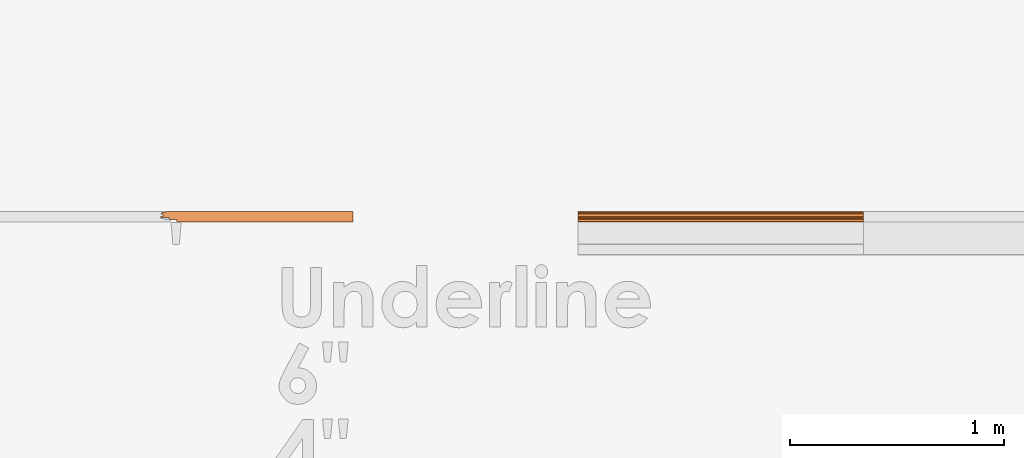
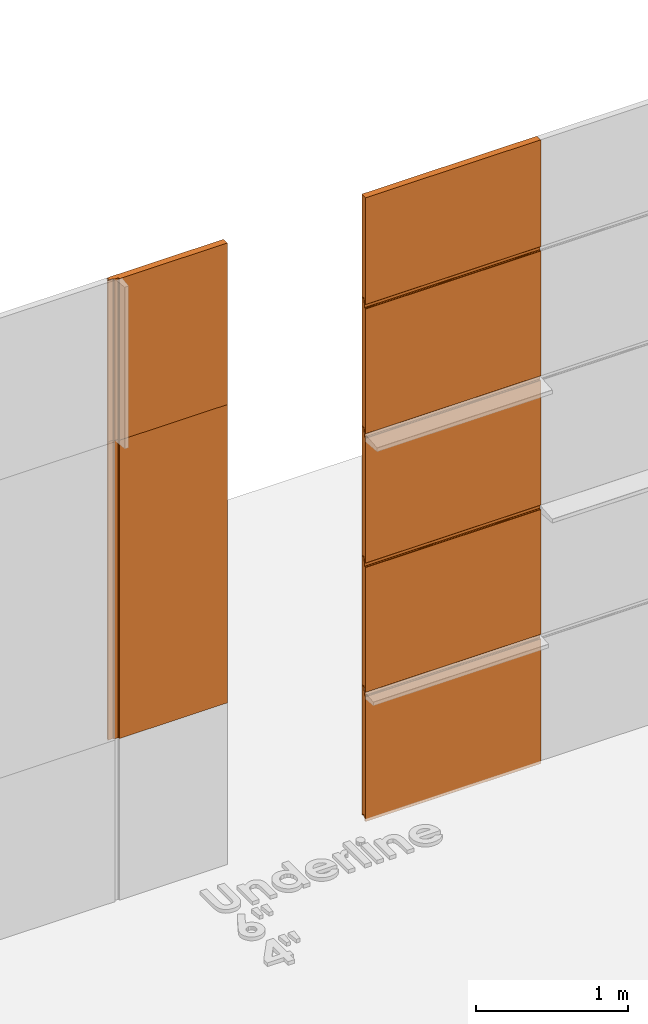
# One storey, part 5 of 6: 7 proxies.
"""IFC2X3 building model written with IfcOpenShell, lengths in millimetres."""

from ifc_helpers import new_model, entity, si_unit, converted_unit, derived_unit, direction, frame, frame_2d, origin, place, context, subcontext, project, spatial, polyline, circle_curve, parameter, trimmed, segment, composite_curve, outline, extrude, source, transform, mapped, material, type_object, type_shapes, element, save


model = new_model("IFC2X3")

# Units and contexts
model_context = context("Model", 3, precision=0.01, world=origin(), true_north=direction((6.123031769111886e-17, 1.0)))
body_context = subcontext(model_context, "Body", "Model", "MODEL_VIEW")
ifc_project = project(units=[si_unit("LENGTHUNIT", "METRE", prefix="MILLI"), si_unit("AREAUNIT", "SQUARE_METRE"), si_unit("VOLUMEUNIT", "CUBIC_METRE"), converted_unit("PLANEANGLEUNIT", "DEGREE", entity("IfcPlaneAngleMeasure", 0.017453292519943278), si_unit("PLANEANGLEUNIT", "RADIAN"), dimensions=[0, 0, 0, 0, 0, 0, 0]), si_unit("MASSUNIT", "GRAM", prefix="KILO"), derived_unit("MASSDENSITYUNIT", [(si_unit("MASSUNIT", "GRAM", prefix="KILO"), 1), (si_unit("LENGTHUNIT", "METRE"), -3)]), derived_unit("IONCONCENTRATIONUNIT", [(si_unit("MASSUNIT", "GRAM", prefix="KILO"), 1), (si_unit("LENGTHUNIT", "METRE"), -3)]), derived_unit("MOMENTOFINERTIAUNIT", [(si_unit("LENGTHUNIT", "METRE"), 4)]), si_unit("TIMEUNIT", "SECOND"), si_unit("FREQUENCYUNIT", "HERTZ"), si_unit("THERMODYNAMICTEMPERATUREUNIT", "DEGREE_CELSIUS"), derived_unit("THERMALTRANSMITTANCEUNIT", [(si_unit("MASSUNIT", "GRAM", prefix="KILO"), 1), (si_unit("THERMODYNAMICTEMPERATUREUNIT", "KELVIN"), -1), (si_unit("TIMEUNIT", "SECOND"), -3)]), derived_unit("THERMALCONDUCTANCEUNIT", [(si_unit("MASSUNIT", "GRAM", prefix="KILO"), 1), (si_unit("THERMODYNAMICTEMPERATUREUNIT", "KELVIN"), -1), (si_unit("TIMEUNIT", "SECOND"), -3), (si_unit("LENGTHUNIT", "METRE"), 1)]), derived_unit("VOLUMETRICFLOWRATEUNIT", [(si_unit("LENGTHUNIT", "METRE", prefix="DECI"), 3), (si_unit("TIMEUNIT", "SECOND"), -1)]), derived_unit("MASSFLOWRATEUNIT", [(si_unit("MASSUNIT", "GRAM", prefix="KILO"), 1), (si_unit("TIMEUNIT", "SECOND"), -1)]), derived_unit("ROTATIONALFREQUENCYUNIT", [(si_unit("TIMEUNIT", "SECOND"), -1)]), si_unit("ELECTRICCURRENTUNIT", "AMPERE"), si_unit("ELECTRICVOLTAGEUNIT", "VOLT"), si_unit("POWERUNIT", "WATT"), si_unit("FORCEUNIT", "NEWTON", prefix="KILO"), si_unit("ILLUMINANCEUNIT", "LUX"), si_unit("LUMINOUSFLUXUNIT", "LUMEN"), si_unit("LUMINOUSINTENSITYUNIT", "CANDELA"), si_unit("ENERGYUNIT", "JOULE"), derived_unit("USERDEFINED", [(si_unit("MASSUNIT", "GRAM", prefix="KILO"), -1), (si_unit("LENGTHUNIT", "METRE"), -2), (si_unit("TIMEUNIT", "SECOND"), 3), (si_unit("LUMINOUSFLUXUNIT", "LUMEN"), 1)]), derived_unit("USERDEFINED", [(si_unit("MASSUNIT", "GRAM", prefix="KILO"), 1), (si_unit("TIMEUNIT", "SECOND"), -3), (si_unit("LENGTHUNIT", "METRE"), 3), (si_unit("ELECTRICCURRENTUNIT", "AMPERE"), -2)]), derived_unit("SOUNDPOWERUNIT", [(si_unit("MASSUNIT", "GRAM", prefix="KILO"), 1), (si_unit("TIMEUNIT", "SECOND"), -3), (si_unit("LENGTHUNIT", "METRE"), 2)]), derived_unit("SOUNDPRESSUREUNIT", [(si_unit("MASSUNIT", "GRAM", prefix="KILO"), 1), (si_unit("LENGTHUNIT", "METRE"), -1), (si_unit("TIMEUNIT", "SECOND"), -2)]), derived_unit("LINEARVELOCITYUNIT", [(si_unit("LENGTHUNIT", "METRE"), 1), (si_unit("TIMEUNIT", "SECOND"), -1)]), si_unit("PRESSUREUNIT", "PASCAL"), derived_unit("USERDEFINED", [(si_unit("MASSUNIT", "GRAM", prefix="KILO"), 1), (si_unit("LENGTHUNIT", "METRE"), -2), (si_unit("TIMEUNIT", "SECOND"), -2)]), derived_unit("LINEARFORCEUNIT", [(si_unit("MASSUNIT", "GRAM", prefix="KILO"), 1), (si_unit("TIMEUNIT", "SECOND"), -2)]), derived_unit("PLANARFORCEUNIT", [(si_unit("MASSUNIT", "GRAM", prefix="KILO"), 1), (si_unit("LENGTHUNIT", "METRE"), -1), (si_unit("TIMEUNIT", "SECOND"), -2)]), derived_unit("SPECIFICHEATCAPACITYUNIT", [(si_unit("THERMODYNAMICTEMPERATUREUNIT", "KELVIN"), -1), (si_unit("LENGTHUNIT", "METRE"), 2), (si_unit("TIMEUNIT", "SECOND"), -2)]), derived_unit("HEATFLUXDENSITYUNIT", [(si_unit("MASSUNIT", "GRAM", prefix="KILO"), 1), (si_unit("TIMEUNIT", "SECOND"), -3)]), derived_unit("HEATINGVALUEUNIT", [(si_unit("LENGTHUNIT", "METRE"), 2), (si_unit("TIMEUNIT", "SECOND"), -2)]), derived_unit("VAPORPERMEABILITYUNIT", [(si_unit("LENGTHUNIT", "METRE"), -1), (si_unit("TIMEUNIT", "SECOND"), 1)]), derived_unit("DYNAMICVISCOSITYUNIT", [(si_unit("MASSUNIT", "GRAM", prefix="KILO"), 1), (si_unit("TIMEUNIT", "SECOND"), -1), (si_unit("LENGTHUNIT", "METRE"), -1)]), derived_unit("THERMALEXPANSIONCOEFFICIENTUNIT", [(si_unit("THERMODYNAMICTEMPERATUREUNIT", "KELVIN"), -1)]), derived_unit("MODULUSOFELASTICITYUNIT", [(si_unit("MASSUNIT", "GRAM", prefix="KILO"), 1), (si_unit("LENGTHUNIT", "METRE"), -1), (si_unit("TIMEUNIT", "SECOND"), -2)]), derived_unit("ISOTHERMALMOISTURECAPACITYUNIT", [(si_unit("MASSUNIT", "GRAM", prefix="KILO"), -1), (si_unit("LENGTHUNIT", "METRE"), 3)]), derived_unit("MOISTUREDIFFUSIVITYUNIT", [(si_unit("TIMEUNIT", "SECOND"), -1), (si_unit("LENGTHUNIT", "METRE"), 2)]), derived_unit("MASSPERLENGTHUNIT", [(si_unit("MASSUNIT", "GRAM", prefix="KILO"), 1), (si_unit("LENGTHUNIT", "METRE"), -1)]), derived_unit("THERMALRESISTANCEUNIT", [(si_unit("MASSUNIT", "GRAM", prefix="KILO"), -1), (si_unit("TIMEUNIT", "SECOND"), 3), (si_unit("THERMODYNAMICTEMPERATUREUNIT", "KELVIN"), 1)]), derived_unit("ACCELERATIONUNIT", [(si_unit("LENGTHUNIT", "METRE"), 1), (si_unit("TIMEUNIT", "SECOND"), -2)]), derived_unit("ANGULARVELOCITYUNIT", [(si_unit("TIMEUNIT", "SECOND"), -1), (si_unit("PLANEANGLEUNIT", "RADIAN"), 1)]), derived_unit("LINEARSTIFFNESSUNIT", [(si_unit("MASSUNIT", "GRAM", prefix="KILO"), 1), (si_unit("TIMEUNIT", "SECOND"), -2)]), derived_unit("WARPINGCONSTANTUNIT", [(si_unit("LENGTHUNIT", "METRE"), 6)]), derived_unit("LINEARMOMENTUNIT", [(si_unit("MASSUNIT", "GRAM", prefix="KILO"), 1), (si_unit("LENGTHUNIT", "METRE"), 1), (si_unit("TIMEUNIT", "SECOND"), -2)]), derived_unit("TORQUEUNIT", [(si_unit("MASSUNIT", "GRAM", prefix="KILO"), 1), (si_unit("LENGTHUNIT", "METRE"), 2), (si_unit("TIMEUNIT", "SECOND"), -2)])], contexts=[model_context])

# Site, building, storey
site_placement = place(None, origin())
site = spatial("IfcSite", under=ifc_project, at=site_placement, CompositionType="ELEMENT")
building_placement = place(site_placement, origin())
building = spatial("IfcBuilding", under=site, at=building_placement, Name="de", CompositionType="ELEMENT")
storey_placement = place(building_placement, origin())
storey = spatial("IfcBuildingStorey", under=building, at=storey_placement, CompositionType="ELEMENT", Elevation=0.0)

# Proxies
ifc_material = material(Name="KSI_RAL9003")
building_element_proxy_type_1 = type_object("IfcBuildingElementProxyType", Name="Painel Evolution:Painel Evolution", PredefinedType="NOTDEFINED", material=ifc_material)
shared_shape_1 = source(origin(), body_context, "Body", "SweptSolid", [
    extrude(outline(composite_curve([segment(trimmed(circle_curve(frame_2d((-541.6373700065079, 10.459449795313603), x_axis=(-1.0, 0.0)), 1.5999999047686129), [parameter(279.9999998873789)], [parameter(358.50454829316124)], True, "PARAMETER"), True, "CONTINUOUS"), segment(polyline([(-543.2368249510248, 10.501205941207395), (-543.2368249510248, 3.880596964632579)]), True, "CONTINUOUS"), segment(trimmed(circle_curve(frame_2d((-542.1914107086996, 3.880596964632576), x_axis=(-1.0, 0.0)), 1.0454142423252974), [parameter(359.9999999999996)], [parameter(90.00000000000009)], True, "PARAMETER"), True, "CONTINUOUS"), segment(polyline([(-542.1914107086996, 2.83518272230729), (-534.2753031299127, 2.835182722321888)]), True, "CONTINUOUS"), segment(trimmed(circle_curve(frame_2d((-534.2753031299127, 0.485182810658933), x_axis=(-1.0, 0.0)), 2.3499999116629553), [parameter(180.00000000000043)], [parameter(269.9999999999999)], True, "PARAMETER"), False, "CONTINUOUS"), segment(polyline([(-531.9253032182644, 0.4851828106589372), (-531.9253032182644, -3.9178716254091968)]), True, "CONTINUOUS"), segment(trimmed(circle_curve(frame_2d((-534.275303129929, -3.917871625409184), x_axis=(-1.0, 0.0)), 2.3499999116645798), [parameter(90.00000000000009)], [parameter(180.0)], True, "PARAMETER"), False, "CONTINUOUS"), segment(polyline([(-534.275303129929, -6.267871537073788), (-544.9447939910186, -6.267871537074008)]), True, "CONTINUOUS"), segment(trimmed(circle_curve(frame_2d((-544.9447939910186, -8.667871537069942), x_axis=(-1.0, 0.0)), 2.399999999995935), [parameter(269.9999999999999)], [parameter(359.99999999999966)], True, "PARAMETER"), True, "CONTINUOUS"), segment(polyline([(-547.3447939910149, -8.667871537069942), (-547.3447939910149, -10.667871311477809)]), True, "CONTINUOUS"), segment(trimmed(circle_curve(frame_2d((-548.9447939910189, -10.667871311477805), x_axis=(-1.0, 0.0)), 1.6000000000039678), [parameter(90.00000000000009)], [parameter(180.0000000000002)], True, "PARAMETER"), False, "CONTINUOUS"), segment(polyline([(-548.9447939910189, -12.267871311481763), (-572.3355503541303, -12.26787131148627)]), True, "CONTINUOUS"), segment(trimmed(circle_curve(frame_2d((-572.3355503541303, -15.967871172331035), x_axis=(-1.0, 0.0)), 3.699999860844765), [parameter(269.9999999999999)], [parameter(350.4980187502896)], True, "PARAMETER"), True, "CONTINUOUS"), segment(polyline([(-575.9847858236225, -15.357068865127594), (-576.4262167541286, -20.400087371498177)]), True, "CONTINUOUS"), segment(trimmed(circle_curve(frame_2d((-572.8754972220172, -20.700390565940353), x_axis=(-1.0, 0.0)), 3.5633960212569518), [parameter(355.16569651713564)], [parameter(88.83791988883837)], True, "PARAMETER"), True, "CONTINUOUS"), segment(polyline([(-572.9477655073729, -24.26305368488658), (429.0782903905062, -24.26305368490059)]), True, "CONTINUOUS"), segment(trimmed(circle_curve(frame_2d((429.02661432000133, -21.373687559574048), x_axis=(-1.0, 0.0)), 2.889828199469197), [parameter(91.024620965678)], [parameter(174.99921945634426)], True, "PARAMETER"), True, "CONTINUOUS"), segment(polyline([(431.90544241925767, -21.625591901172886), (432.65194514225794, -13.094365331982997)]), True, "CONTINUOUS"), segment(trimmed(circle_curve(frame_2d((434.6718091241544, -13.271108258981247), x_axis=(-1.0, 0.0)), 2.0275819508977904), [parameter(322.50238491495514)], [parameter(354.9992194748408)], True, "PARAMETER"), False, "CONTINUOUS"), segment(trimmed(circle_curve(frame_2d((434.6499261921662, -13.25431834245234), x_axis=(-1.0, 0.0)), 2.000000000331924), [parameter(269.7752197054467)], [parameter(322.50238490067886)], True, "PARAMETER"), False, "CONTINUOUS"), segment(polyline([(434.6577724845074, -11.254333733262063), (464.6446978830772, -11.254333733258877)]), True, "CONTINUOUS"), segment(trimmed(circle_curve(frame_2d((464.6446978830757, -8.454333717516795), x_axis=(-1.0, 0.0)), 2.8000000157420852), [parameter(90.00000000003057)], [parameter(180.00000000002854)], True, "PARAMETER"), True, "CONTINUOUS"), segment(polyline([(467.4446978988198, -8.45433371751389), (467.44469789904696, -6.163773190028205)]), True, "CONTINUOUS"), segment(trimmed(circle_curve(frame_2d((470.4446979072005, -6.163773190028211), x_axis=(-1.0, 0.0)), 3.000000008153628), [parameter(269.9999999999947)], [parameter(4.0711099922733055e-13)], True, "PARAMETER"), False, "CONTINUOUS"), segment(polyline([(470.4446979072011, -3.1637731816474877), (492.4821726913916, -3.1637731816475423)]), True, "CONTINUOUS"), segment(trimmed(circle_curve(frame_2d((492.4821726913916, -4.763773183527278), x_axis=(-1.0, 0.0)), 1.6000000018797356), [parameter(221.0795546756581)], [parameter(270.00000000000233)], True, "PARAMETER"), False, "CONTINUOUS"), segment(trimmed(circle_curve(frame_2d((496.43523715110086, -1.9925479235228443), x_axis=(-1.0, 0.0)), 3.2409633915334344), [parameter(32.05017476117218)], [parameter(61.522805713472586)], True, "PARAMETER"), True, "CONTINUOUS"), segment(trimmed(circle_curve(frame_2d((496.00254394635044, -2.714863509877051), x_axis=(-1.0, 0.0)), 2.4000000000014894), [parameter(62.38069466751207)], [parameter(92.2671756846998)], True, "PARAMETER"), True, "CONTINUOUS"), segment(polyline([(496.0974863986537, -5.11298484349589), (504.442623351026, -5.112984843495904)]), True, "CONTINUOUS"), segment(trimmed(circle_curve(frame_2d((504.4426233510259, -1.8442935298604415), x_axis=(-1.0, 0.0)), 3.268691313635463), [parameter(90.00000000000126)], [parameter(266.64922463269517)], True, "PARAMETER"), True, "CONTINUOUS"), segment(polyline([(504.63367421393616, 1.4188096667328296), (496.7914226707592, 1.4188096667328491)]), True, "CONTINUOUS"), segment(polyline([(496.7914226707592, 1.4188096667328491), (496.79142267075923, 13.229214081882997)]), True, "CONTINUOUS"), segment(polyline([(496.79142267075923, 13.229214081882997), (500.32479033585236, 13.22921408188327)]), True, "CONTINUOUS"), segment(trimmed(circle_curve(frame_2d((499.51496654021736, 16.736946315110515), x_axis=(-1.0, 0.0)), 3.599999999999723), [parameter(102.99999999995242)], [parameter(269.99999999999886)], True, "PARAMETER"), True, "CONTINUOUS"), segment(polyline([(499.5149665402175, 20.336946315110506), (489.7149665402197, 20.33694631511163)]), True, "CONTINUOUS"), segment(trimmed(circle_curve(frame_2d((489.7149665402197, 22.336946315111717), x_axis=(-1.0, 0.0)), 2.0000000000000866), [parameter(3.5622212432391423e-13)], [parameter(90.00000000000202)], True, "PARAMETER"), False, "CONTINUOUS"), segment(polyline([(487.71496654021854, 22.336946315111724), (487.71496654021854, 23.736946315111506)]), True, "CONTINUOUS"), segment(trimmed(circle_curve(frame_2d((485.7149665402189, 23.73694631511151), x_axis=(-1.0, 0.0)), 1.9999999999995453), [parameter(179.99999999999983)], [parameter(269.99999999999795)], True, "PARAMETER"), True, "CONTINUOUS"), segment(polyline([(485.7149665402189, 25.736946315111073), (-547.7850334597792, 25.736946315115553)]), True, "CONTINUOUS"), segment(trimmed(circle_curve(frame_2d((-547.7850334597792, 23.23694631511558), x_axis=(-1.0, 0.0)), 2.499999999999973), [parameter(269.9999999999999)], [parameter(90.00000000000009)], True, "PARAMETER"), True, "CONTINUOUS"), segment(polyline([(-547.7850334597794, 20.736946315117518), (-538.5134802227543, 20.736946315115397)]), True, "CONTINUOUS"), segment(trimmed(circle_curve(frame_2d((-538.5134802227543, 16.38604421100607), x_axis=(-1.0, 0.0)), 4.350902104109325), [parameter(90.00000000000009)], [parameter(269.9999999999999)], True, "PARAMETER"), False, "CONTINUOUS"), segment(polyline([(-538.5134802227543, 12.03514210689464), (-541.9152070711411, 12.03514210689464)]), True, "CONTINUOUS")], self_intersect=False)), frame((-30.32409595977936, -0.7369463151145117, 0.0), z_axis=(0.0, 0.0, -1.0), x_axis=(-1.0, 0.0, 0.0)), (0.0, 0.0, -1.0), 1333.3333333333342),
])
type_shapes(building_element_proxy_type_1, [shared_shape_1])
for number, where, z_axis, x_axis, name in (
    (1, (321.33447730813805, 792.6007792258446, 520.0), (1.0, 0.0, 0.0), (0.0, 0.0, -1.0), "Painel Evolution:Painel Evolution"),
    (2, (321.33447730813776, 792.6007792258459, 1560.0), (1.0, 0.0, 0.0), (0.0, 0.0, -1.0), "Painel Evolution:Painel Evolution"),
    (3, (321.33447730813765, 792.6007792258459, 2600.0), (1.0, 0.0, 0.0), (0.0, 0.0, -1.0), "Painel Evolution:Painel Evolution"),
    (4, (321.33447730813765, 792.6007792258459, 3640.0), (1.0, 0.0, 0.0), (0.0, 0.0, -1.0), "Painel Evolution:Painel Evolution"),
):
    element("IfcBuildingElementProxy", number, at=place(storey_placement, frame(where, z_axis=z_axis, x_axis=x_axis)), inside=storey, type_object=building_element_proxy_type_1, material=ifc_material, Name=name, ObjectType="Painel Evolution:Painel Evolution", context=body_context, shape_type="MappedRepresentation", body=[
        mapped(shared_shape_1, transform((0.0, 0.0, 0.0), scale=1.0)),
    ])
building_element_proxy_type_2 = type_object("IfcBuildingElementProxyType", Name="Painel Evolution:Painel Evolution", PredefinedType="NOTDEFINED", material=ifc_material)
shared_shape_2 = source(origin(), body_context, "Body", "SweptSolid", [
    extrude(outline(composite_curve([segment(trimmed(circle_curve(frame_2d((-78.46681410675188, 23.336917179009085), x_axis=(1.0, 0.0)), 1.9999999999995453), [parameter(90.00000000000202)], [parameter(180.00000000000017)], True, "PARAMETER"), True, "CONTINUOUS"), segment(polyline([(-80.46681410675154, 23.336917179009085), (-80.46681410675154, 21.936917179009303)]), True, "CONTINUOUS"), segment(trimmed(circle_curve(frame_2d((-82.46681410675268, 21.936917179009303), x_axis=(1.0, 0.0)), 2.0000000000000866), [parameter(269.99999999999795)], [parameter(359.99999999999966)], True, "PARAMETER"), False, "CONTINUOUS"), segment(polyline([(-82.46681410675268, 19.936917179009214), (-92.26681410675047, 19.936917179008116)]), True, "CONTINUOUS"), segment(trimmed(circle_curve(frame_2d((-92.26681410675036, 16.336917179008125), x_axis=(1.0, 0.0)), 3.599999999999723), [parameter(90.00000000000115)], [parameter(257.0000000000476)], True, "PARAMETER"), True, "CONTINUOUS"), segment(polyline([(-93.07663790238536, 12.829184945780879), (-89.54327023729223, 12.829184945780598)]), True, "CONTINUOUS"), segment(polyline([(-89.54327023729223, 12.829184945780598), (-89.54327023729223, 1.01878053063045)]), True, "CONTINUOUS"), segment(polyline([(-89.54327023729223, 1.01878053063045), (-97.38552178046922, 1.01878053063045)]), True, "CONTINUOUS"), segment(trimmed(circle_curve(frame_2d((-97.19447091755893, -2.2443226659628213), x_axis=(1.0, 0.0)), 3.268691313635463), [parameter(93.35077536730483)], [parameter(269.99999999999875)], True, "PARAMETER"), True, "CONTINUOUS"), segment(polyline([(-97.19447091755904, -5.513013979598285), (-88.84933396518676, -5.513013979598291)]), True, "CONTINUOUS"), segment(trimmed(circle_curve(frame_2d((-88.7543915128835, -3.1148926459794515), x_axis=(1.0, 0.0)), 2.4000000000014894), [parameter(267.7328243153002)], [parameter(297.61930533248795)], True, "PARAMETER"), True, "CONTINUOUS"), segment(trimmed(circle_curve(frame_2d((-89.18708471763392, -2.3925770596252445), x_axis=(1.0, 0.0)), 3.2409633915334344), [parameter(298.47719428652744)], [parameter(327.9498252388278)], True, "PARAMETER"), True, "CONTINUOUS"), segment(trimmed(circle_curve(frame_2d((-85.23402025792467, -5.1638023196296885), x_axis=(1.0, 0.0)), 1.6000000018797356), [parameter(89.9999999999977)], [parameter(138.9204453243419)], True, "PARAMETER"), False, "CONTINUOUS"), segment(polyline([(-85.23402025792467, -3.5638023177499525), (-63.19654547373415, -3.5638023177499525)]), True, "CONTINUOUS"), segment(trimmed(circle_curve(frame_2d((-63.19654547373358, -6.563802326130676), x_axis=(1.0, 0.0)), 3.000000008153628), [parameter(359.9999999999996)], [parameter(90.00000000000529)], True, "PARAMETER"), False, "CONTINUOUS"), segment(polyline([(-60.196545465580016, -6.563802326130677), (-60.19654546535287, -8.854362853616363)]), True, "CONTINUOUS"), segment(trimmed(circle_curve(frame_2d((-57.396545449608766, -8.854362853619273), x_axis=(1.0, 0.0)), 2.8000000157420852), [parameter(179.99999999997146)], [parameter(269.9999999999694)], True, "PARAMETER"), True, "CONTINUOUS"), segment(polyline([(-57.396545449610244, -11.654362869361355), (-27.409620051040463, -11.654362869364617)]), True, "CONTINUOUS"), segment(trimmed(circle_curve(frame_2d((-27.401773758699335, -13.654347478554893), x_axis=(1.0, 0.0)), 2.000000000331924), [parameter(37.497615099321145)], [parameter(90.2247802945533)], True, "PARAMETER"), False, "CONTINUOUS"), segment(trimmed(circle_curve(frame_2d((-27.423656690687494, -13.6711373950838), x_axis=(1.0, 0.0)), 2.0275819508977904), [parameter(5.000780525159224)], [parameter(37.49761508504483)], True, "PARAMETER"), False, "CONTINUOUS"), segment(polyline([(-25.40379270879106, -13.494394468085556), (-24.657289985790783, -22.025621037275446)]), True, "CONTINUOUS"), segment(trimmed(circle_curve(frame_2d((-21.778461886534444, -21.773716695676615), x_axis=(1.0, 0.0)), 2.889828199469197), [parameter(185.00078054365574)], [parameter(268.975379034322)], True, "PARAMETER"), True, "CONTINUOUS"), segment(polyline([(-21.830137957039312, -24.663082821003158), (797.5722480884465, -24.663082820993743)]), True, "CONTINUOUS"), segment(polyline([(797.5722480884465, -24.663082820993743), (797.5722480884465, 25.33691717901027)]), True, "CONTINUOUS"), segment(polyline([(797.5722480884465, 25.33691717901027), (-78.46681410675188, 25.336917179008648)]), True, "CONTINUOUS")], self_intersect=False)), frame((-437.5722483932463, -0.33691717901087714, 0.0)), (0.0, 0.0, 1.0), 1300.0000000000005),
])
type_shapes(building_element_proxy_type_2, [shared_shape_2])
proxy_1_placement = place(storey_placement, frame((-1090.0510342028456, 792.600779225854, 3700.0)))
element("IfcBuildingElementProxy", 5, at=proxy_1_placement, inside=storey, type_object=building_element_proxy_type_2, material=ifc_material, Name="Painel Evolution:Painel Evolution", ObjectType="Painel Evolution:Painel Evolution", context=body_context, shape_type="MappedRepresentation", body=[
    mapped(shared_shape_2, transform((0.0, 0.0, 0.0), scale=1.0)),
])
building_element_proxy_type_3 = type_object("IfcBuildingElementProxyType", Name="Painel Evolution:Painel Evolution", PredefinedType="NOTDEFINED", material=ifc_material)
shared_shape_3 = source(origin(), body_context, "Body", "SweptSolid", [
    extrude(outline(composite_curve([segment(trimmed(circle_curve(frame_2d((-69.24830272831227, 10.78003811995571), x_axis=(-1.0, 0.0)), 1.5999999047686129), [parameter(279.9999998873789)], [parameter(358.50454829316124)], True, "PARAMETER"), True, "CONTINUOUS"), segment(polyline([(-70.84775767282915, 10.821794265849501), (-70.84775767282916, 4.201185289274686)]), True, "CONTINUOUS"), segment(trimmed(circle_curve(frame_2d((-69.80234343050391, 4.201185289274683), x_axis=(-1.0, 0.0)), 1.0454142423252974), [parameter(359.9999999999996)], [parameter(90.00000000000009)], True, "PARAMETER"), True, "CONTINUOUS"), segment(polyline([(-69.80234343050385, 3.1557710469493974), (-61.88623585171705, 3.1557710469639955)]), True, "CONTINUOUS"), segment(trimmed(circle_curve(frame_2d((-61.88623585171706, 0.8057711353010405), x_axis=(-1.0, 0.0)), 2.3499999116629553), [parameter(180.00000000000043)], [parameter(269.9999999999999)], True, "PARAMETER"), False, "CONTINUOUS"), segment(polyline([(-59.536235940068764, 0.8057711353010448), (-59.53623594006877, -3.59728330076709)]), True, "CONTINUOUS"), segment(trimmed(circle_curve(frame_2d((-61.886235851733325, -3.5972833007670766), x_axis=(-1.0, 0.0)), 2.3499999116645798), [parameter(90.00000000000009)], [parameter(180.0)], True, "PARAMETER"), False, "CONTINUOUS"), segment(polyline([(-61.88623585173333, -5.947283212431681), (-72.55572671282302, -5.947283212431901)]), True, "CONTINUOUS"), segment(trimmed(circle_curve(frame_2d((-72.55572671282302, -8.347283212427834), x_axis=(-1.0, 0.0)), 2.399999999995935), [parameter(269.9999999999999)], [parameter(359.99999999999966)], True, "PARAMETER"), True, "CONTINUOUS"), segment(polyline([(-74.95572671281924, -8.347283212427834), (-74.95572671281926, -10.347282986835701)]), True, "CONTINUOUS"), segment(trimmed(circle_curve(frame_2d((-76.55572671282326, -10.3472829868357), x_axis=(-1.0, 0.0)), 1.6000000000039678), [parameter(90.00000000000009)], [parameter(180.0000000000002)], True, "PARAMETER"), False, "CONTINUOUS"), segment(polyline([(-76.55572671282326, -11.947282986839657), (-99.94648307593471, -11.947282986844161)]), True, "CONTINUOUS"), segment(trimmed(circle_curve(frame_2d((-99.94648307593472, -15.647282847688928), x_axis=(-1.0, 0.0)), 3.699999860844765), [parameter(269.9999999999999)], [parameter(350.4980187502896)], True, "PARAMETER"), True, "CONTINUOUS"), segment(polyline([(-103.59571854542689, -15.036480540485487), (-104.03714947593306, -20.07949904685607)]), True, "CONTINUOUS"), segment(trimmed(circle_curve(frame_2d((-100.48642994382163, -20.379802241298247), x_axis=(-1.0, 0.0)), 3.5633960212569518), [parameter(355.16569651713564)], [parameter(88.83791988883837)], True, "PARAMETER"), True, "CONTINUOUS"), segment(polyline([(-100.5586982291772, -23.942465360244473), (757.0353282913596, -23.942465360256467)]), True, "CONTINUOUS"), segment(polyline([(757.0353282913596, -23.942465360256467), (757.0353282913599, 26.057534639754053)]), True, "CONTINUOUS"), segment(polyline([(757.0353282913599, 26.057534639754053), (-75.39596618158366, 26.057534639757662)]), True, "CONTINUOUS"), segment(trimmed(circle_curve(frame_2d((-75.39596618158367, 23.55753463975769), x_axis=(-1.0, 0.0)), 2.499999999999973), [parameter(269.9999999999999)], [parameter(90.00000000000009)], True, "PARAMETER"), True, "CONTINUOUS"), segment(polyline([(-75.39596618158367, 21.057534639759627), (-66.12441294455857, 21.057534639757503)]), True, "CONTINUOUS"), segment(trimmed(circle_curve(frame_2d((-66.12441294455859, 16.706632535648176), x_axis=(-1.0, 0.0)), 4.350902104109325), [parameter(90.00000000000009)], [parameter(269.9999999999999)], True, "PARAMETER"), False, "CONTINUOUS"), segment(polyline([(-66.1244129445586, 12.355730431536747), (-69.52613979294549, 12.355730431536745)]), True, "CONTINUOUS")], self_intersect=False)), frame((442.06497131841627, -1.057534639757794, 0.0), z_axis=(0.0, 0.0, -1.0), x_axis=(-1.0, 0.0, 0.0)), (0.0, 0.0, -1.0), 1333.3333333333337),
])
type_shapes(building_element_proxy_type_3, [shared_shape_3])
proxy_2_placement = place(storey_placement, frame((321.3344773081379, 792.6007792258458, 4680.0), z_axis=(1.0, 0.0, 0.0), x_axis=(0.0, 0.0, -1.0)))
element("IfcBuildingElementProxy", 6, at=proxy_2_placement, inside=storey, type_object=building_element_proxy_type_3, material=ifc_material, Name="Painel Evolution:Painel Evolution", ObjectType="Painel Evolution:Painel Evolution", context=body_context, shape_type="MappedRepresentation", body=[
    mapped(shared_shape_3, transform((0.0, 0.0, 0.0), scale=1.0)),
])
building_element_proxy_type_4 = type_object("IfcBuildingElementProxyType", Name="Painel Evolution:Painel Evolution", PredefinedType="NOTDEFINED", material=ifc_material)
shared_shape_4 = source(origin(), body_context, "Body", "SweptSolid", [
    extrude(outline(composite_curve([segment(trimmed(circle_curve(frame_2d((-78.46681410675205, 23.336917179009085), x_axis=(1.0, 0.0)), 1.9999999999995453), [parameter(90.00000000000202)], [parameter(180.00000000000017)], True, "PARAMETER"), True, "CONTINUOUS"), segment(polyline([(-80.46681410675171, 23.336917179009085), (-80.46681410675171, 21.936917179009303)]), True, "CONTINUOUS"), segment(trimmed(circle_curve(frame_2d((-82.46681410675285, 21.936917179009303), x_axis=(1.0, 0.0)), 2.0000000000000866), [parameter(269.99999999999795)], [parameter(359.99999999999966)], True, "PARAMETER"), False, "CONTINUOUS"), segment(polyline([(-82.46681410675285, 19.936917179009214), (-92.26681410675064, 19.936917179008116)]), True, "CONTINUOUS"), segment(trimmed(circle_curve(frame_2d((-92.26681410675053, 16.336917179008125), x_axis=(1.0, 0.0)), 3.599999999999723), [parameter(90.00000000000115)], [parameter(257.0000000000476)], True, "PARAMETER"), True, "CONTINUOUS"), segment(polyline([(-93.07663790238553, 12.829184945780879), (-89.5432702372924, 12.829184945780598)]), True, "CONTINUOUS"), segment(polyline([(-89.5432702372924, 12.829184945780598), (-89.5432702372924, 1.0187805306304503)]), True, "CONTINUOUS"), segment(polyline([(-89.5432702372924, 1.0187805306304503), (-97.38552178046939, 1.0187805306304503)]), True, "CONTINUOUS"), segment(trimmed(circle_curve(frame_2d((-97.1944709175591, -2.2443226659628213), x_axis=(1.0, 0.0)), 3.268691313635463), [parameter(93.35077536730483)], [parameter(269.99999999999875)], True, "PARAMETER"), True, "CONTINUOUS"), segment(polyline([(-97.19447091755922, -5.513013979598284), (-88.84933396518693, -5.51301397959829)]), True, "CONTINUOUS"), segment(trimmed(circle_curve(frame_2d((-88.75439151288367, -3.1148926459794515), x_axis=(1.0, 0.0)), 2.4000000000014894), [parameter(267.7328243153002)], [parameter(297.61930533248795)], True, "PARAMETER"), True, "CONTINUOUS"), segment(trimmed(circle_curve(frame_2d((-89.1870847176341, -2.392577059625244), x_axis=(1.0, 0.0)), 3.2409633915334344), [parameter(298.47719428652744)], [parameter(327.9498252388278)], True, "PARAMETER"), True, "CONTINUOUS"), segment(trimmed(circle_curve(frame_2d((-85.23402025792484, -5.163802319629688), x_axis=(1.0, 0.0)), 1.6000000018797356), [parameter(89.9999999999977)], [parameter(138.9204453243419)], True, "PARAMETER"), False, "CONTINUOUS"), segment(polyline([(-85.23402025792484, -3.563802317749952), (-63.19654547373432, -3.563802317749952)]), True, "CONTINUOUS"), segment(trimmed(circle_curve(frame_2d((-63.19654547373375, -6.563802326130675), x_axis=(1.0, 0.0)), 3.000000008153628), [parameter(359.9999999999996)], [parameter(90.00000000000529)], True, "PARAMETER"), False, "CONTINUOUS"), segment(polyline([(-60.196545465580186, -6.563802326130676), (-60.19654546535304, -8.854362853616363)]), True, "CONTINUOUS"), segment(trimmed(circle_curve(frame_2d((-57.39654544960894, -8.854362853619273), x_axis=(1.0, 0.0)), 2.8000000157420852), [parameter(179.99999999997146)], [parameter(269.9999999999694)], True, "PARAMETER"), True, "CONTINUOUS"), segment(polyline([(-57.396545449610414, -11.654362869361355), (-27.409620051040633, -11.654362869364617)]), True, "CONTINUOUS"), segment(trimmed(circle_curve(frame_2d((-27.401773758699505, -13.654347478554893), x_axis=(1.0, 0.0)), 2.000000000331924), [parameter(37.497615099321145)], [parameter(90.2247802945533)], True, "PARAMETER"), False, "CONTINUOUS"), segment(trimmed(circle_curve(frame_2d((-27.423656690687665, -13.6711373950838), x_axis=(1.0, 0.0)), 2.0275819508977904), [parameter(5.000780525159224)], [parameter(37.49761508504483)], True, "PARAMETER"), False, "CONTINUOUS"), segment(polyline([(-25.40379270879123, -13.494394468085556), (-24.657289985790953, -22.025621037275446)]), True, "CONTINUOUS"), segment(trimmed(circle_curve(frame_2d((-21.778461886534615, -21.773716695676615), x_axis=(1.0, 0.0)), 2.889828199469197), [parameter(185.00078054365574)], [parameter(268.975379034322)], True, "PARAMETER"), True, "CONTINUOUS"), segment(polyline([(-21.830137957039483, -24.663082821003158), (797.5722480884465, -24.663082820993743)]), True, "CONTINUOUS"), segment(polyline([(797.5722480884465, -24.663082820993747), (797.5722480884465, 25.336917179010268)]), True, "CONTINUOUS"), segment(polyline([(797.5722480884465, 25.336917179010268), (-78.46681410675205, 25.336917179008648)]), True, "CONTINUOUS")], self_intersect=False)), frame((-437.5722483932461, -0.3369171790108774, 0.0)), (0.0, 0.0, 1.0), 2400.000000000001),
])
type_shapes(building_element_proxy_type_4, [shared_shape_4])
proxy_3_placement = place(storey_placement, frame((-1090.0510342028458, 792.600779225854, 1300.0)))
element("IfcBuildingElementProxy", 7, at=proxy_3_placement, inside=storey, type_object=building_element_proxy_type_4, material=ifc_material, Name="Painel Evolution:Painel Evolution", ObjectType="Painel Evolution:Painel Evolution", context=body_context, shape_type="MappedRepresentation", body=[
    mapped(shared_shape_4, transform((0.0, 0.0, 0.0), scale=1.0)),
])

save(model, "model.ifc")
